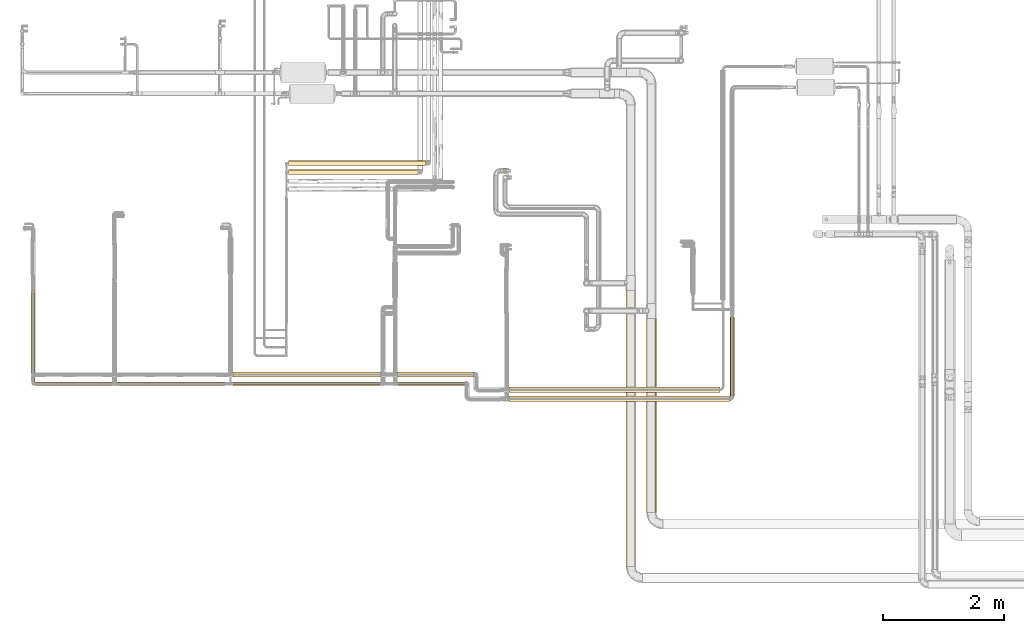
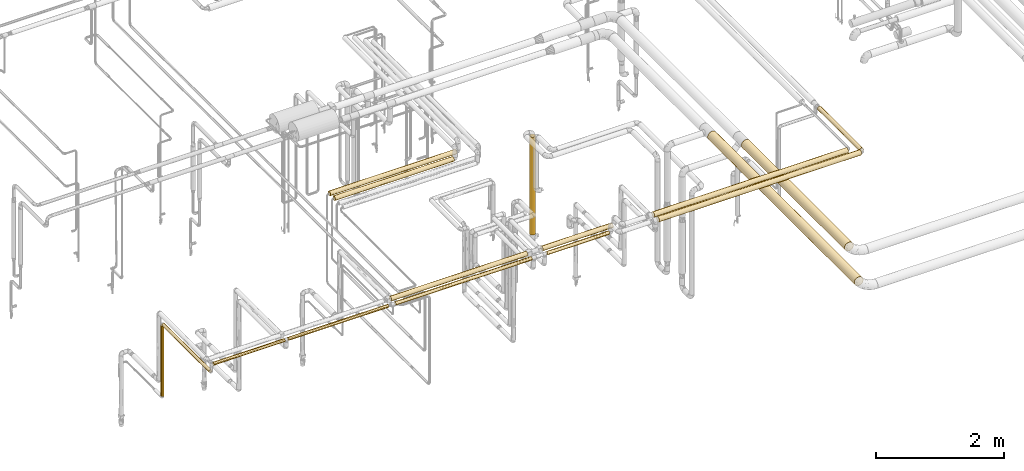
# One storey, part 1 of 827: 16 coverings.
"""IFC2X3 building model written with IfcOpenShell, lengths in millimetres."""

from ifc_helpers import new_model, entity, si_unit, converted_unit, derived_unit, direction, frame, origin, origin_2d_with_axis, place, context, subcontext, project, spatial, circle, extrude, element, save


model = new_model("IFC2X3")

# Units and contexts
model_context = context("Model", 3, precision=0.01, world=origin(), true_north=direction((6.12303176911189e-17, 1.0)))
body_context = subcontext(model_context, "Body", "Model", "MODEL_VIEW")
ifc_project = project(units=[si_unit("LENGTHUNIT", "METRE", prefix="MILLI"), si_unit("AREAUNIT", "SQUARE_METRE"), si_unit("VOLUMEUNIT", "CUBIC_METRE"), converted_unit("PLANEANGLEUNIT", "DEGREE", entity("IfcRatioMeasure", 0.0174532925199433), si_unit("PLANEANGLEUNIT", "RADIAN"), dimensions=[0, 0, 0, 0, 0, 0, 0]), si_unit("MASSUNIT", "GRAM", prefix="KILO"), derived_unit("MASSDENSITYUNIT", [(si_unit("MASSUNIT", "GRAM", prefix="KILO"), 1), (si_unit("LENGTHUNIT", "METRE"), -3)]), derived_unit("MOMENTOFINERTIAUNIT", [(si_unit("LENGTHUNIT", "METRE"), 4)]), si_unit("TIMEUNIT", "SECOND"), si_unit("FREQUENCYUNIT", "HERTZ"), si_unit("THERMODYNAMICTEMPERATUREUNIT", "DEGREE_CELSIUS"), derived_unit("THERMALTRANSMITTANCEUNIT", [(si_unit("MASSUNIT", "GRAM", prefix="KILO"), 1), (si_unit("THERMODYNAMICTEMPERATUREUNIT", "KELVIN"), -1), (si_unit("TIMEUNIT", "SECOND"), -3)]), derived_unit("VOLUMETRICFLOWRATEUNIT", [(si_unit("LENGTHUNIT", "METRE"), 3), (si_unit("TIMEUNIT", "SECOND"), -1)]), derived_unit("MASSFLOWRATEUNIT", [(si_unit("MASSUNIT", "GRAM", prefix="KILO"), 1), (si_unit("TIMEUNIT", "SECOND"), -1)]), derived_unit("ROTATIONALFREQUENCYUNIT", [(si_unit("TIMEUNIT", "SECOND"), -1)]), si_unit("ELECTRICCURRENTUNIT", "AMPERE"), si_unit("ELECTRICVOLTAGEUNIT", "VOLT"), si_unit("POWERUNIT", "WATT"), si_unit("FORCEUNIT", "NEWTON", prefix="KILO"), si_unit("ILLUMINANCEUNIT", "LUX"), si_unit("LUMINOUSFLUXUNIT", "LUMEN"), si_unit("LUMINOUSINTENSITYUNIT", "CANDELA"), derived_unit("USERDEFINED", [(si_unit("MASSUNIT", "GRAM", prefix="KILO"), -1), (si_unit("LENGTHUNIT", "METRE"), -2), (si_unit("TIMEUNIT", "SECOND"), 3), (si_unit("LUMINOUSFLUXUNIT", "LUMEN"), 1)]), derived_unit("LINEARVELOCITYUNIT", [(si_unit("LENGTHUNIT", "METRE"), 1), (si_unit("TIMEUNIT", "SECOND"), -1)]), si_unit("PRESSUREUNIT", "PASCAL"), derived_unit("USERDEFINED", [(si_unit("LENGTHUNIT", "METRE"), -2), (si_unit("MASSUNIT", "GRAM", prefix="KILO"), 1), (si_unit("TIMEUNIT", "SECOND"), -2)]), derived_unit("LINEARFORCEUNIT", [(si_unit("MASSUNIT", "GRAM", prefix="KILO"), 1), (si_unit("LENGTHUNIT", "METRE"), 1), (si_unit("TIMEUNIT", "SECOND"), -2), (si_unit("LENGTHUNIT", "METRE"), -1)]), derived_unit("PLANARFORCEUNIT", [(si_unit("MASSUNIT", "GRAM", prefix="KILO"), 1), (si_unit("LENGTHUNIT", "METRE"), 1), (si_unit("TIMEUNIT", "SECOND"), -2), (si_unit("LENGTHUNIT", "METRE"), -2)])], contexts=[model_context])

# Site, building, storey
site_placement = place(None, origin())
site = spatial("IfcSite", under=ifc_project, at=site_placement, CompositionType="ELEMENT")
building_placement = place(site_placement, origin())
building = spatial("IfcBuilding", under=site, at=building_placement, CompositionType="ELEMENT")
storey_placement = place(building_placement, frame((0.0, 0.0, 28200.0)))
storey = spatial("IfcBuildingStorey", under=building, at=storey_placement, Name="08", CompositionType="ELEMENT", Elevation=28200.0)

# Coverings
covering_1_placement = place(storey_placement, frame((11901.91, 9621.9, 2670.0)))
element("IfcCovering", 1, at=covering_1_placement, inside=storey, Name=":ADSK_", ObjectType=":ADSK_", PredefinedType="INSULATION", context=body_context, shape_type="SweptSolid", body=[
    extrude(circle(Radius=28.4, at=origin_2d_with_axis()), frame((30.0, 0.0, 30.0), z_axis=(0.0, 1.0, 0.0), x_axis=(-1.0, 0.0, 0.0)), (0.0, 0.0, 1.0), 1466.8851148285),
])
covering_2_placement = place(storey_placement, frame((11901.91, 11087.89, 1328.45)))
element("IfcCovering", 2, at=covering_2_placement, inside=storey, Name=":ADSK_", ObjectType=":ADSK_", PredefinedType="INSULATION", context=body_context, shape_type="SweptSolid", body=[
    extrude(circle(Radius=28.4, at=origin_2d_with_axis()), frame((30.0, 30.0, 0.0)), (0.0, 0.0, 1.0), 1342.44557612682),
])
covering_3_placement = place(storey_placement, frame((11961.01, 9562.8, 2820.0)))
element("IfcCovering", 3, at=covering_3_placement, inside=storey, Name=":ADSK_", ObjectType=":ADSK_", PredefinedType="INSULATION", context=body_context, shape_type="SweptSolid", body=[
    extrude(circle(Radius=28.4, at=origin_2d_with_axis()), frame((0.0, 30.0, 30.0), z_axis=(1.0, 0.0, 0.0), x_axis=(0.0, 1.0, 0.0)), (0.0, 0.0, 1.0), 1287.54289948289),
])
covering_4_placement = place(storey_placement, frame((15238.92, 9559.45, 2816.65)))
element("IfcCovering", 4, at=covering_4_placement, inside=storey, Name=":ADSK_", ObjectType=":ADSK_", PredefinedType="INSULATION", context=body_context, shape_type="SweptSolid", body=[
    extrude(circle(Radius=31.75, at=origin_2d_with_axis()), frame((0.0, 33.35, 33.35), z_axis=(1.0, 0.0, 0.0), x_axis=(0.0, -1.0, 0.0)), (0.0, 0.0, 1.0), 2451.60029353856),
])
covering_5_placement = place(storey_placement, frame((17966.53, 9559.45, 2816.65)))
element("IfcCovering", 5, at=covering_5_placement, inside=storey, Name=":ADSK_", ObjectType=":ADSK_", PredefinedType="INSULATION", context=body_context, shape_type="SweptSolid", body=[
    extrude(circle(Radius=31.75, at=origin_2d_with_axis()), frame((0.0, 33.35, 33.35), z_axis=(1.0, 0.0, 0.0), x_axis=(0.0, -1.0, 0.0)), (0.0, 0.0, 1.0), 1117.61105241123),
])
covering_6_placement = place(storey_placement, frame((23476.64, 9390.8, 2958.64)))
element("IfcCovering", 6, at=covering_6_placement, inside=storey, Name=":ADSK_", ObjectType=":ADSK_", PredefinedType="INSULATION", context=body_context, shape_type="SweptSolid", body=[
    extrude(circle(Radius=36.15, at=origin_2d_with_axis()), frame((37.75, 0.0, 37.75), z_axis=(0.0, 0.999999997129731, 7.57663358726185e-05), x_axis=(0.0, -7.57663358726185e-05, 0.999999997129731)), (0.0, 0.0, 1.0), 1310.59110257094),
])
covering_7_placement = place(storey_placement, frame((22091.66, 7456.2, 2716.91)))
element("IfcCovering", 7, at=covering_7_placement, inside=storey, Name=":ADSK_", ObjectType=":ADSK_", PredefinedType="INSULATION", context=body_context, shape_type="SweptSolid", body=[
    extrude(circle(Radius=81.5, at=origin_2d_with_axis()), frame((83.1, 0.0, 83.1), z_axis=(0.0, 1.0, 0.0), x_axis=(-0.707106781186549, 0.0, 0.707106781186546)), (0.0, 0.0, 1.0), 3219.44443281138),
])
covering_8_placement = place(storey_placement, frame((21752.01, 6565.0, 2716.9)))
element("IfcCovering", 8, at=covering_8_placement, inside=storey, Name=":ADSK_", ObjectType=":ADSK_", PredefinedType="INSULATION", context=body_context, shape_type="SweptSolid", body=[
    extrude(circle(Radius=81.5, at=origin_2d_with_axis()), frame((83.1, 0.0, 83.1), z_axis=(0.0, 1.0, 0.0), x_axis=(-1.0, 0.0, 0.0)), (0.0, 0.0, 1.0), 4570.64796604332),
])
covering_9_placement = place(storey_placement, frame((13306.55, 9562.8, 2820.0)))
element("IfcCovering", 9, at=covering_9_placement, inside=storey, Name=":ADSK_", ObjectType=":ADSK_", PredefinedType="INSULATION", context=body_context, shape_type="SweptSolid", body=[
    extrude(circle(Radius=28.4, at=origin_2d_with_axis()), frame((0.0, 30.0, 30.0), z_axis=(1.0, 0.0, 0.0), x_axis=(0.0, -1.0, 0.0)), (0.0, 0.0, 1.0), 1805.37544866203),
])
covering_10_placement = place(storey_placement, frame((15238.92, 9699.45, 2806.7)))
element("IfcCovering", 10, at=covering_10_placement, inside=storey, Name=":ADSK_", ObjectType=":ADSK_", PredefinedType="INSULATION", context=body_context, shape_type="SweptSolid", body=[
    extrude(circle(Radius=41.75, at=origin_2d_with_axis()), frame((2451.6, 43.35, 43.35), z_axis=(-1.0, 0.0, 1.9264196019509e-05), x_axis=(0.0, 1.0, 0.0)), (0.0, 0.0, 1.0), 2451.60034154369),
])
covering_11_placement = place(storey_placement, frame((17966.52, 9699.45, 2806.67)))
element("IfcCovering", 11, at=covering_11_placement, inside=storey, Name=":ADSK_", ObjectType=":ADSK_", PredefinedType="INSULATION", context=body_context, shape_type="SweptSolid", body=[
    extrude(circle(Radius=41.75, at=origin_2d_with_axis()), frame((1262.96, 43.35, 43.35), z_axis=(-1.0, 0.0, 1.92641960195394e-05), x_axis=(0.0, 1.0, 0.0)), (0.0, 0.0, 1.0), 1262.95794134026),
])
covering_12_placement = place(storey_placement, frame((19824.27, 9295.05, 2948.72)))
element("IfcCovering", 12, at=covering_12_placement, inside=storey, Name=":ADSK_", ObjectType=":ADSK_", PredefinedType="INSULATION", context=body_context, shape_type="SweptSolid", body=[
    extrude(circle(Radius=46.15, at=origin_2d_with_axis()), frame((0.0, 47.75, 47.75), z_axis=(1.0, 0.0, 0.0), x_axis=(0.0, 7.57660976682567e-05, -0.999999997129749)), (0.0, 0.0, 1.0), 3642.11493062337),
])
covering_13_placement = place(storey_placement, frame((19824.27, 9445.05, 2949.41)))
element("IfcCovering", 13, at=covering_13_placement, inside=storey, Name=":ADSK_", ObjectType=":ADSK_", PredefinedType="INSULATION", context=body_context, shape_type="SweptSolid", body=[
    extrude(circle(Radius=46.15, at=origin_2d_with_axis()), frame((3491.04, 47.75, 47.75), z_axis=(-1.0, 0.0, 1.92641960183011e-05), x_axis=(1.92641960183011e-05, 0.0, 1.0)), (0.0, 0.0, 1.0), 3491.04340109456),
])
covering_14_placement = place(storey_placement, frame((19703.4, 13073.77, 461.5)))
element("IfcCovering", 14, at=covering_14_placement, inside=storey, Name=":ADSK_", ObjectType=":ADSK_", PredefinedType="INSULATION", context=body_context, shape_type="SweptSolid", body=[
    extrude(circle(Radius=45.0, at=origin_2d_with_axis()), frame((46.6, 46.6, 0.0), z_axis=(0.0, 0.0, 1.0), x_axis=(0.0, -1.0, 0.0)), (0.0, 0.0, 1.0), 1862.5),
])
covering_15_placement = place(storey_placement, frame((16166.05, 13206.65, 2356.65)))
element("IfcCovering", 15, at=covering_15_placement, inside=storey, Name=":ADSK_", ObjectType=":ADSK_", PredefinedType="INSULATION", context=body_context, shape_type="SweptSolid", body=[
    extrude(circle(Radius=41.75, at=origin_2d_with_axis()), frame((0.0, 43.35, 43.35), z_axis=(1.0, 0.0, 0.0), x_axis=(0.0, 1.0, 0.0)), (0.0, 0.0, 1.0), 2276.50487666268),
])
covering_16_placement = place(storey_placement, frame((16166.05, 13056.65, 2356.27)))
element("IfcCovering", 16, at=covering_16_placement, inside=storey, Name=":ADSK_", ObjectType=":ADSK_", PredefinedType="INSULATION", context=body_context, shape_type="SweptSolid", body=[
    extrude(circle(Radius=41.75, at=origin_2d_with_axis()), frame((0.01, 43.35, 43.73), z_axis=(0.999999984094241, 0.0, -0.000178357837292143), x_axis=(0.0, 1.0, 0.0)), (0.0, 0.0, 1.0), 2141.49184794441),
])

save(model, "model.ifc")
